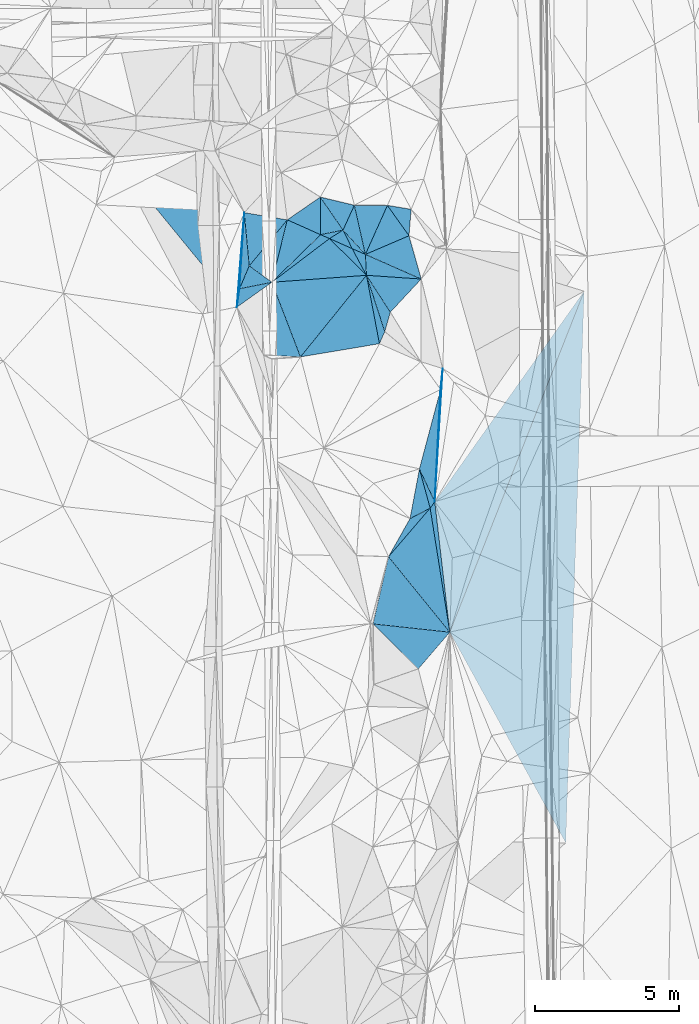
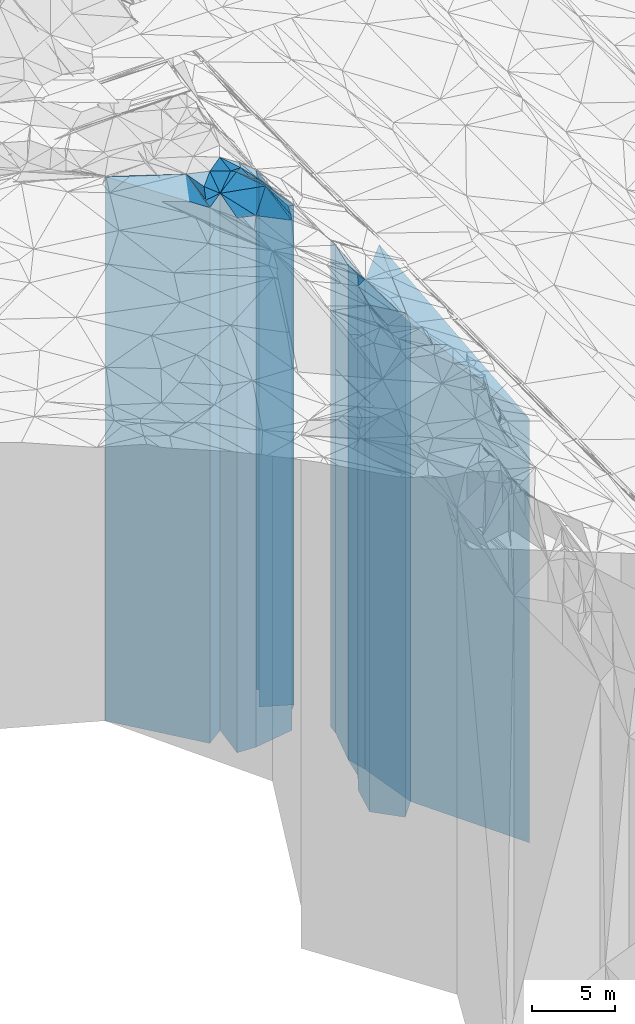
# One storey, part 207 of 275: 41 plates.
"""IFC2X3 building model written with IfcOpenShell, lengths in millimetres."""

from ifc_helpers import new_model, si_unit, frame, origin_with_axes, place, context, subcontext, project, spatial, faceted_brep, material, type_object, element, save


model = new_model("IFC2X3")

# Units and contexts
model_context = context("Model", 3, precision=1e-05, world=origin_with_axes())
body_context = subcontext(model_context, "Body", "Model", "MODEL_VIEW")
ifc_project = project(units=[si_unit("LENGTHUNIT", "METRE", prefix="MILLI"), si_unit("AREAUNIT", "SQUARE_METRE"), si_unit("VOLUMEUNIT", "CUBIC_METRE"), si_unit("MASSUNIT", "GRAM", prefix="KILO"), si_unit("TIMEUNIT", "SECOND"), si_unit("PLANEANGLEUNIT", "RADIAN"), si_unit("SOLIDANGLEUNIT", "STERADIAN"), si_unit("THERMODYNAMICTEMPERATUREUNIT", "DEGREE_CELSIUS"), si_unit("LUMINOUSINTENSITYUNIT", "LUMEN")], contexts=[model_context])

# Site, building, storey
site_placement = place(None, origin_with_axes())
site = spatial("IfcSite", under=ifc_project, at=site_placement, CompositionType="ELEMENT")
building_placement = place(site_placement, origin_with_axes())
building = spatial("IfcBuilding", under=site, at=building_placement, Name="Undefined", CompositionType="ELEMENT")
storey_placement = place(building_placement, origin_with_axes())
storey = spatial("IfcBuildingStorey", under=building, at=storey_placement, Name="Undefined", CompositionType="ELEMENT", Elevation=0.0)

# Plates
ifc_material = material()
plate_type_1 = type_object("IfcPlateType", PredefinedType="NOTDEFINED")
plate_1_placement = place(storey_placement, frame((-100408.430234477, 49733.2246878095, 26274.0), z_axis=(-0.393281517051527, 0.919418103120474, 0.0), x_axis=(0.919418103120471, 0.393281517051532, 0.0)))
element("IfcPlate", 1, at=plate_1_placement, inside=storey, type_object=plate_type_1, material=ifc_material, Name="00", context=body_context, shape_type="Brep", body=[
    faceted_brep([(0.0, -20336.0, -7.27595761418343e-12), (1374.74743652344, -19706.0, 1266.75537109374), (1374.74743652344, 18446.0, 1266.75537109374), (0.0, 18446.0, 0.0), (1650.12121582033, -18446.0, 1.64436642080545e-09), (1650.12121582033, 18446.0, 1.64436642080545e-09)], [[[0, 1, 2, 3]], [[1, 4, 5, 2]], [[4, 0, 3, 5]], [[5, 3, 2]], [[4, 1, 0]]]),
])
plate_type_2 = type_object("IfcPlateType", PredefinedType="NOTDEFINED")
plate_2_placement = place(storey_placement, frame((-99642.6539960685, 51438.5653437163, 26904.0), z_axis=(-0.00455352299844871, -0.999989632660411, 0.0), x_axis=(-0.99998963266041, 0.00455352299845431, 0.0)))
element("IfcPlate", 2, at=plate_2_placement, inside=storey, type_object=plate_type_2, material=ifc_material, Name="00", context=body_context, shape_type="Brep", body=[
    faceted_brep([(1.45519152283669e-11, -19076.0, -7.27595761418343e-12), (758.002990722671, -19706.0, 1708.80993652344), (758.002990722671, 19076.0, 1708.80993652344), (1.45519152283669e-11, 19076.0, -7.27595761418343e-12), (1150.39123535158, -20026.0, 2.77941580861807e-09), (1150.39123535158, 19076.0, 2.77941580861807e-09)], [[[0, 1, 2, 3]], [[1, 4, 5, 2]], [[4, 0, 3, 5]], [[5, 3, 2]], [[4, 1, 0]]]),
])
plate_type_3 = type_object("IfcPlateType", PredefinedType="NOTDEFINED")
plate_3_placement = place(storey_placement, frame((-98816.4230019084, 51300.9341543399, 26224.0), z_axis=(-0.164313055978836, -0.986408241872956, 0.0), x_axis=(-0.986408241872953, 0.164313055978852, 0.0)))
element("IfcPlate", 3, at=plate_3_placement, inside=storey, type_object=plate_type_3, material=ifc_material, Name="00", context=body_context, shape_type="Brep", body=[
    faceted_brep([(1.45519152283669e-11, -18396.0, -1.45519152283669e-11), (-77.1236801147315, -18496.0, 918.559692382798), (-77.1236801147315, 18396.0, 918.559692382798), (-1.45519152283669e-11, 18396.0, 1.45519152283669e-11), (837.615661621123, -19756.0, 2.09547579288483e-09), (837.615661621123, 18396.0, 2.09547579288483e-09)], [[[0, 1, 2, 3]], [[1, 4, 5, 2]], [[4, 0, 3, 5]], [[5, 3, 2]], [[4, 1, 0]]]),
])
plate_type_4 = type_object("IfcPlateType", PredefinedType="NOTDEFINED")
plate_4_placement = place(storey_placement, frame((-101969.740987989, 50420.5446503939, 27524.0), z_axis=(-0.200360374967368, 0.979722266840422, 0.0), x_axis=(0.979722266840424, 0.200360374967362, 0.0)))
element("IfcPlate", 4, at=plate_4_placement, inside=storey, type_object=plate_type_4, material=ifc_material, Name="00", context=body_context, shape_type="Brep", body=[
    faceted_brep([(0.0, -19816.0, 0.0), (252.533248901367, -20046.0, 1283.20959472656), (252.533248901367, 19696.0, 1283.20959472656), (0.0, 19696.0, 0.0), (798.310729980454, -19696.0, -2.00816430151463e-09), (798.310729980454, 19696.0, -2.00816430151463e-09)], [[[0, 1, 2, 3]], [[1, 4, 5, 2]], [[4, 0, 3, 5]], [[5, 3, 2]], [[4, 1, 0]]]),
])
plate_type_5 = type_object("IfcPlateType", PredefinedType="NOTDEFINED")
plate_5_placement = place(storey_placement, frame((-101969.740987989, 50420.5446503939, 27524.0), z_axis=(0.399271495028854, 0.91683274006627, 0.0), x_axis=(0.916832740066268, -0.399271495028857, 0.0)))
element("IfcPlate", 5, at=plate_5_placement, inside=storey, type_object=plate_type_5, material=ifc_material, Name="00", context=body_context, shape_type="Brep", body=[
    faceted_brep([(0.0, -19816.0, 0.0), (653.212341308594, -19696.0, 458.926574707033), (653.212341308594, 19696.0, 458.926574707033), (0.0, 19696.0, 0.0), (339.705749511704, -19726.0, -9.00399754755199e-10), (339.705749511704, 19696.0, -9.00399754755199e-10)], [[[0, 1, 2, 3]], [[1, 4, 5, 2]], [[4, 0, 3, 5]], [[5, 3, 2]], [[4, 1, 0]]]),
])
plate_type_6 = type_object("IfcPlateType", PredefinedType="NOTDEFINED")
plate_6_placement = place(storey_placement, frame((-101187.618203258, 50580.4944850444, 27304.0), z_axis=(0.531830128137156, -0.846851058218396, 0.0), x_axis=(-0.846851058218394, -0.531830128137159, 0.0)))
element("IfcPlate", 6, at=plate_6_placement, inside=storey, type_object=plate_type_6, material=ifc_material, Name="00", context=body_context, shape_type="Brep", body=[
    faceted_brep([(0.0, -19916.0, 0.0), (73.9490966796802, -19476.0, 716.820434570298), (73.9490966796802, 19476.0, 716.820434570298), (1.45519152283669e-11, 19476.0, -1.45519152283669e-11), (555.787719726563, -19946.0, -2.75031197816134e-09), (555.787719726563, 19476.0, -2.75031197816134e-09)], [[[0, 1, 2, 3]], [[1, 4, 5, 2]], [[4, 0, 3, 5]], [[5, 3, 2]], [[4, 1, 0]]]),
])
plate_type_7 = type_object("IfcPlateType", PredefinedType="NOTDEFINED")
plate_7_placement = place(storey_placement, frame((-103664.468272729, 48763.6803136547, 27539.0), z_axis=(-0.604209837063284, 0.796825246083456, 0.0), x_axis=(0.796825246083456, 0.604209837063283, 0.0)))
element("IfcPlate", 7, at=plate_7_placement, inside=storey, type_object=plate_type_7, material=ifc_material, Name="00", context=body_context, shape_type="Brep", body=[
    faceted_brep([(7.27595761418343e-12, -19761.0, -2.91038304567337e-11), (2351.49511718751, -19801.0, 296.260437011704), (2351.49511718751, 19711.0, 296.260437011704), (7.27595761418343e-12, 19711.0, 0.0), (2517.71728515625, -19711.0, -1.25874066725373e-08), (2517.71728515625, 19711.0, -1.25874066725373e-08)], [[[0, 1, 2, 3]], [[1, 4, 5, 2]], [[4, 0, 3, 5]], [[5, 3, 2]], [[4, 1, 0]]]),
])
plate_type_8 = type_object("IfcPlateType", PredefinedType="NOTDEFINED")
plate_8_placement = place(storey_placement, frame((-101979.432902652, 51728.3313557821, 27584.0), z_axis=(0.567831637088504, -0.823144721128301, 0.0), x_axis=(-0.823144721128298, -0.567831637088509, 0.0)))
element("IfcPlate", 8, at=plate_8_placement, inside=storey, type_object=plate_type_8, material=ifc_material, Name="00", context=body_context, shape_type="Brep", body=[
    faceted_brep([(0.0, -19986.0, 0.0), (734.624816894531, -19756.0, 1082.00109863281), (734.624816894531, 19756.0, 1082.00109863281), (-1.45519152283669e-11, 19756.0, -1.45519152283669e-11), (1394.45324707032, -19836.0, -1.16415321826935e-09), (1394.45324707032, 19756.0, -1.16415321826935e-09)], [[[0, 1, 2, 3]], [[1, 4, 5, 2]], [[4, 0, 3, 5]], [[5, 3, 2]], [[4, 1, 0]]]),
])
plate_type_9 = type_object("IfcPlateType", PredefinedType="NOTDEFINED")
plate_9_placement = place(storey_placement, frame((-100371.23257535, 49006.1646255344, 27184.0), z_axis=(-0.88121869398494, -0.472708803991926, 0.0), x_axis=(-0.472708803991917, 0.881218693984944, 0.0)))
element("IfcPlate", 9, at=plate_9_placement, inside=storey, type_object=plate_type_9, material=ifc_material, Name="00", context=body_context, shape_type="Brep", body=[
    faceted_brep([(-3.63797880709171e-12, -19356.0, 0.0), (1735.25646972656, -20066.0, 529.702880859346), (1735.25646972656, 19356.0, 529.702880859346), (0.0, 19356.0, -1.45519152283669e-11), (1053.04321289063, -19596.0, -5.82076609134674e-10), (1053.04321289063, 19356.0, -5.82076609134674e-10)], [[[0, 1, 2, 3]], [[1, 4, 5, 2]], [[4, 0, 3, 5]], [[5, 3, 2]], [[4, 1, 0]]]),
])
plate_type_10 = type_object("IfcPlateType", PredefinedType="NOTDEFINED")
plate_10_placement = place(storey_placement, frame((-100793.03330737, 51443.8036764334, 27379.0), z_axis=(-0.233211575093592, -0.972426018390276, 0.0), x_axis=(-0.972426018390275, 0.233211575093599, 0.0)))
element("IfcPlate", 10, at=plate_10_placement, inside=storey, type_object=plate_type_10, material=ifc_material, Name="00", context=body_context, shape_type="Brep", body=[
    faceted_brep([(1.45519152283669e-11, -19551.0, 3.63797880709171e-12), (182.370925903335, -19841.0, 931.526062011722), (182.370925903335, 19551.0, 931.526062011722), (8.18545231595635e-12, 19551.0, 0.0), (1220.04101562501, -20191.0, -2.24463292397559e-09), (1220.04101562501, 19551.0, -2.24463292397559e-09)], [[[0, 1, 2, 3]], [[1, 4, 5, 2]], [[4, 0, 3, 5]], [[5, 3, 2]], [[4, 1, 0]]]),
])
plate_type_11 = type_object("IfcPlateType", PredefinedType="NOTDEFINED")
plate_11_placement = place(storey_placement, frame((-100371.23257535, 49006.1646255344, 27184.0), z_axis=(-0.998693801805313, -0.0510949139900409, 0.0), x_axis=(-0.0510949139900386, 0.998693801805313, 0.0)))
element("IfcPlate", 11, at=plate_11_placement, inside=storey, type_object=plate_type_11, material=ifc_material, Name="00", context=body_context, shape_type="Brep", body=[
    faceted_brep([(-3.63797880709171e-12, -19356.0, 0.0), (952.183410644539, -19596.0, 449.718475341811), (952.183410644539, 19356.0, 449.718475341811), (0.0, 19356.0, -1.45519152283669e-11), (728.010986328132, -19426.0, 1.46974343806505e-09), (728.010986328132, 19356.0, 1.46974343806505e-09)], [[[0, 1, 2, 3]], [[1, 4, 5, 2]], [[4, 0, 3, 5]], [[5, 3, 2]], [[4, 1, 0]]]),
])
plate_type_12 = type_object("IfcPlateType", PredefinedType="NOTDEFINED")
plate_12_placement = place(storey_placement, frame((-101187.618203258, 50580.4944850444, 27219.0), z_axis=(0.896955755285538, 0.442120315140744, 0.0), x_axis=(0.442120315140746, -0.896955755285537, 0.0)))
element("IfcPlate", 12, at=plate_12_placement, inside=storey, type_object=plate_type_12, material=ifc_material, Name="00", context=body_context, shape_type="Brep", body=[
    faceted_brep([(8.18545231595635e-12, -20001.0, 0.0), (1104.45837402344, -19391.0, 324.301940917969), (1104.45837402344, 19391.0, 324.301940917969), (7.27595761418343e-12, 19391.0, 0.0), (720.624755859375, -19561.0, -4.65661287307739e-10), (720.624755859375, 19391.0, -4.65661287307739e-10)], [[[0, 1, 2, 3]], [[1, 4, 5, 2]], [[4, 0, 3, 5]], [[5, 3, 2]], [[4, 1, 0]]]),
])
plate_type_13 = type_object("IfcPlateType", PredefinedType="NOTDEFINED")
plate_13_placement = place(storey_placement, frame((-100793.03330737, 51443.8036764334, 27219.0), z_axis=(0.909502651009569, -0.415698121004374, 0.0), x_axis=(-0.415698121004381, -0.909502651009566, 0.0)))
element("IfcPlate", 13, at=plate_13_placement, inside=storey, type_object=plate_type_13, material=ifc_material, Name="00", context=body_context, shape_type="Brep", body=[
    faceted_brep([(-9.09494701772928e-13, -19711.0, -1.45519152283669e-11), (1395.89733886719, -19391.0, 1060.88195800781), (1395.89733886719, 19391.0, 1060.88195800781), (7.27595761418343e-12, 19391.0, 0.0), (949.210205078124, -20001.0, -2.6775524020195e-09), (949.210205078124, 19391.0, -2.6775524020195e-09)], [[[0, 1, 2, 3]], [[1, 4, 5, 2]], [[4, 0, 3, 5]], [[5, 3, 2]], [[4, 1, 0]]]),
])
plate_type_14 = type_object("IfcPlateType", PredefinedType="NOTDEFINED")
plate_14_placement = place(storey_placement, frame((-103664.468272729, 48763.6803136547, 27564.0), z_axis=(-0.699073984699882, 0.715049343693027, 0.0), x_axis=(0.715049343204323, 0.699073985199754, 0.0)))
element("IfcPlate", 14, at=plate_14_placement, inside=storey, type_object=plate_type_14, material=ifc_material, Name="00", context=body_context, shape_type="Brep", body=[
    faceted_brep([(0.0, -19736.0, 0.0), (1903.0968009342, -19856.0, 1178.14367675781), (1903.0968009342, 19736.0, 1178.14367675781), (0.0, 19736.0, 0.0), (2370.08447265626, -19776.0, 2.47382558882236e-10), (2370.08447265626, 19736.0, 2.47382558882236e-10)], [[[0, 1, 2, 3]], [[1, 4, 5, 2]], [[4, 0, 3, 5]], [[5, 3, 2]], [[4, 1, 0]]]),
])
plate_type_15 = type_object("IfcPlateType", PredefinedType="NOTDEFINED")
plate_15_placement = place(storey_placement, frame((-99734.2828294801, 47046.3444753073, 26609.0), z_axis=(-0.961490975586377, 0.274836503881774, 0.0), x_axis=(0.274836503881771, 0.961490975586378, 0.0)))
element("IfcPlate", 15, at=plate_15_placement, inside=storey, type_object=plate_type_15, material=ifc_material, Name="00", context=body_context, shape_type="Brep", body=[
    faceted_brep([(1.45519152283669e-11, -18781.0, 4.54747350886464e-12), (1709.29235839843, -19931.0, 1151.05151367186), (1709.29235839843, 18781.0, 1151.05151367186), (-1.45519152283669e-11, 18781.0, 4.54747350886464e-13), (702.922485351559, -18951.0, -2.4156179279089e-09), (702.922485351559, 18781.0, -2.4156179279089e-09)], [[[0, 1, 2, 3]], [[1, 4, 5, 2]], [[4, 0, 3, 5]], [[5, 3, 2]], [[4, 1, 0]]]),
])
plate_type_16 = type_object("IfcPlateType", PredefinedType="NOTDEFINED")
plate_16_placement = place(storey_placement, frame((-100408.430234477, 49733.2246878095, 26174.0), z_axis=(0.998693801805313, 0.0510949139900409, 0.0), x_axis=(0.0510949139900391, -0.998693801805313, 0.0)))
element("IfcPlate", 16, at=plate_16_placement, inside=storey, type_object=plate_type_16, material=ifc_material, Name="00", context=body_context, shape_type="Brep", body=[
    faceted_brep([(-9.09494701772928e-13, -20436.0, 1.45519152283669e-11), (955.754821777351, -18346.0, 1896.39990234374), (955.754821777351, 18346.0, 1896.39990234374), (-2.91038304567337e-11, 18346.0, -2.91038304567337e-11), (728.010986328125, -20366.0, 1.45519152283669e-09), (728.010986328125, 18346.0, 1.45519152283669e-09)], [[[0, 1, 2, 3]], [[1, 4, 5, 2]], [[4, 0, 3, 5]], [[5, 3, 2]], [[4, 1, 0]]]),
])
plate_type_17 = type_object("IfcPlateType", PredefinedType="NOTDEFINED")
plate_17_placement = place(storey_placement, frame((-99919.8785007401, 46625.3287430484, 26564.0), z_axis=(-0.915035399072081, 0.403373547031778, 0.0), x_axis=(0.403373547031776, 0.915035399072081, 0.0)))
element("IfcPlate", 17, at=plate_17_placement, inside=storey, type_object=plate_type_17, material=ifc_material, Name="00", context=body_context, shape_type="Brep", body=[
    faceted_brep([(-1.45519152283669e-11, -18736.0, -1.45519152283669e-11), (1996.48486328124, -19976.0, 1373.37121582031), (1996.48486328124, 18736.0, 1373.37121582031), (-5.91171556152403e-12, 18736.0, 1.45519152283669e-11), (460.108673095697, -18826.0, 6.25732354819775e-10), (460.108673095697, 18736.0, 6.25732354819775e-10)], [[[0, 1, 2, 3]], [[1, 4, 5, 2]], [[4, 0, 3, 5]], [[5, 3, 2]], [[4, 1, 0]]]),
])
plate_type_18 = type_object("IfcPlateType", PredefinedType="NOTDEFINED")
plate_18_placement = place(storey_placement, frame((-100371.23257535, 49006.1646255344, 26174.0), z_axis=(0.839767991664275, 0.542945411782944, 0.0), x_axis=(0.542945411782941, -0.839767991664277, 0.0)))
element("IfcPlate", 18, at=plate_18_placement, inside=storey, type_object=plate_type_18, material=ifc_material, Name="00", context=body_context, shape_type="Brep", body=[
    faceted_brep([(-1.45519152283669e-11, -20366.0, -1.45519152283669e-11), (1144.24645996094, -18346.0, 1529.34631347656), (1144.24645996094, 18346.0, 1529.34631347656), (-2.91038304567337e-11, 18346.0, -2.91038304567337e-11), (1528.95385742186, -19386.0, 1.74622982740402e-09), (1528.95385742186, 18346.0, 1.74622982740402e-09)], [[[0, 1, 2, 3]], [[1, 4, 5, 2]], [[4, 0, 3, 5]], [[5, 3, 2]], [[4, 1, 0]]]),
])
plate_type_19 = type_object("IfcPlateType", PredefinedType="NOTDEFINED")
plate_19_placement = place(storey_placement, frame((-104452.30723777, 49333.7765907551, 27564.0), z_axis=(0.920337161759967, -0.391125949897994, 0.0), x_axis=(-0.391125949897986, -0.920337161759971, 0.0)))
element("IfcPlate", 19, at=plate_19_placement, inside=storey, type_object=plate_type_19, material=ifc_material, Name="00", context=body_context, shape_type="Brep", body=[
    faceted_brep([(1.45519152283669e-11, -20166.0, -1.45519152283669e-11), (216.536529541008, -19736.0, 948.056945800781), (216.536529541008, 19736.0, 948.056945800781), (0.0, 19736.0, 0.0), (863.133850097649, -19766.0, 1.32422428578138e-09), (863.133850097649, 19736.0, 1.32422428578138e-09)], [[[0, 1, 2, 3]], [[1, 4, 5, 2]], [[4, 0, 3, 5]], [[5, 3, 2]], [[4, 1, 0]]]),
])
plate_type_20 = type_object("IfcPlateType", PredefinedType="NOTDEFINED")
plate_20_placement = place(storey_placement, frame((-103127.269773389, 50936.516656389, 27624.0), z_axis=(-0.165444380043675, -0.986219122260344, 0.0), x_axis=(-0.986219122260344, 0.165444380043675, 0.0)))
element("IfcPlate", 20, at=plate_20_placement, inside=storey, type_object=plate_type_20, material=ifc_material, Name="00", context=body_context, shape_type="Brep", body=[
    faceted_brep([(-7.27595761418343e-12, -19796.0, -1.45519152283669e-11), (1041.61291503908, -20106.0, 1799.87292480468), (1041.61291503908, 19796.0, 1799.87292480468), (-7.27595761418343e-12, 19796.0, -1.45519152283669e-11), (1519.6240234375, -19956.0, -4.86761564388871e-09), (1519.6240234375, 19796.0, -4.86761564388871e-09)], [[[0, 1, 2, 3]], [[1, 4, 5, 2]], [[4, 0, 3, 5]], [[5, 3, 2]], [[4, 1, 0]]]),
])
plate_type_21 = type_object("IfcPlateType", PredefinedType="NOTDEFINED")
plate_21_placement = place(storey_placement, frame((-103127.269773389, 50936.516656389, 27564.0), z_axis=(0.77071736266349, -0.637177170721797, 0.0), x_axis=(-0.637177170721795, -0.770717362663492, 0.0)))
element("IfcPlate", 21, at=plate_21_placement, inside=storey, type_object=plate_type_21, material=ifc_material, Name="00", context=body_context, shape_type="Brep", body=[
    faceted_brep([(1.09139364212751e-11, -19856.0, 1.45519152283669e-11), (2016.93334960938, -19736.0, 970.453491210923), (2016.93334960938, 19736.0, 970.453491210923), (0.0, 19736.0, 0.0), (2079.54321289063, -20166.0, 4.32191882282496e-09), (2079.54321289063, 19736.0, 4.32191882282496e-09)], [[[0, 1, 2, 3]], [[1, 4, 5, 2]], [[4, 0, 3, 5]], [[5, 3, 2]], [[4, 1, 0]]]),
])
plate_type_22 = type_object("IfcPlateType", PredefinedType="NOTDEFINED")
plate_22_placement = place(storey_placement, frame((-100371.23257535, 49006.1646255344, 26564.0), z_axis=(0.77768926512532, -0.628648874101307, 0.0), x_axis=(-0.628648874101305, -0.777689265125321, 0.0)))
element("IfcPlate", 22, at=plate_22_placement, inside=storey, type_object=plate_type_22, material=ifc_material, Name="00", context=body_context, shape_type="Brep", body=[
    faceted_brep([(-1.45519152283669e-11, -19976.0, 0.0), (1567.80725097655, -18736.0, 1847.72302246094), (1567.80725097655, 18736.0, 1847.72302246094), (-5.91171556152403e-12, 18736.0, 1.45519152283669e-11), (3653.95678710938, -20316.0, 1.9950675778091e-08), (3653.95678710938, 18736.0, 1.9950675778091e-08)], [[[0, 1, 2, 3]], [[1, 4, 5, 2]], [[4, 0, 3, 5]], [[5, 3, 2]], [[4, 1, 0]]]),
])
plate_type_23 = type_object("IfcPlateType", PredefinedType="NOTDEFINED")
plate_23_placement = place(storey_placement, frame((-101658.287629832, 50284.9098256165, 27184.0), z_axis=(0.604209837063284, -0.796825246083456, 0.0), x_axis=(-0.796825246083457, -0.604209837063283, 0.0)))
element("IfcPlate", 23, at=plate_23_placement, inside=storey, type_object=plate_type_23, material=ifc_material, Name="00", context=body_context, shape_type="Brep", body=[
    faceted_brep([(1.45519152283669e-11, -20066.0, 0.0), (-252.927536010728, -19356.0, 1796.58776855469), (-252.927536010728, 19356.0, 1796.58776855469), (0.0, 19356.0, -1.45519152283669e-11), (2517.71728515626, -20116.0, -1.2572854757309e-08), (2517.71728515626, 19356.0, -1.2572854757309e-08)], [[[0, 1, 2, 3]], [[1, 4, 5, 2]], [[4, 0, 3, 5]], [[5, 3, 2]], [[4, 1, 0]]]),
])
plate_type_24 = type_object("IfcPlateType", PredefinedType="NOTDEFINED")
plate_24_placement = place(storey_placement, frame((-104452.30723777, 49333.7765907551, 27579.0), z_axis=(-0.995643309864272, -0.0932437639872878, 0.0), x_axis=(-0.0932437639872891, 0.995643309864272, 0.0)))
element("IfcPlate", 24, at=plate_24_placement, inside=storey, type_object=plate_type_24, material=ifc_material, Name="00", context=body_context, shape_type="Brep", body=[
    faceted_brep([(0.0, -20151.0, 0.0), (-759.434753417969, -19751.0, 410.193664550767), (-759.434753417969, 19751.0, 410.193664550767), (0.0, 19751.0, 0.0), (1862.2666015625, -20001.0, 5.42786438018084e-09), (1862.2666015625, 19751.0, 5.42786438018084e-09)], [[[0, 1, 2, 3]], [[1, 4, 5, 2]], [[4, 0, 3, 5]], [[5, 3, 2]], [[4, 1, 0]]]),
])
plate_type_25 = type_object("IfcPlateType", PredefinedType="NOTDEFINED")
plate_25_placement = place(storey_placement, frame((-103954.609665335, 46229.9246087185, 27354.0), z_axis=(0.0507793469886415, 0.99870989677654, 0.0), x_axis=(0.99870989677654, -0.0507793469886369, 0.0)))
element("IfcPlate", 25, at=plate_25_placement, inside=storey, type_object=plate_type_25, material=ifc_material, Name="00", context=body_context, shape_type="Brep", body=[
    faceted_brep([(-7.27595761418343e-12, -19796.0, -1.45519152283669e-11), (161.104614257813, -19946.0, 2545.21997070313), (161.104614257813, 19526.0, 2545.21997070313), (0.0, 19526.0, 0.0), (1287.98291015626, -19526.0, -1.54250301420689e-09), (1287.98291015626, 19526.0, -1.54250301420689e-09)], [[[0, 1, 2, 3]], [[1, 4, 5, 2]], [[4, 0, 3, 5]], [[5, 3, 2]], [[4, 1, 0]]]),
])
plate_type_26 = type_object("IfcPlateType", PredefinedType="NOTDEFINED")
plate_26_placement = place(storey_placement, frame((-104789.901274975, 48539.4024559526, 27510.0), z_axis=(-0.998089556565869, 0.0617837929731288, 0.0), x_axis=(0.061783792973124, 0.99808955656587, 0.0)))
element("IfcPlate", 26, at=plate_26_placement, inside=storey, type_object=plate_type_26, material=ifc_material, Name="00", context=body_context, shape_type="Brep", body=[
    faceted_brep([(0.0, -19820.0, 0.0), (-646.142944335945, -19682.0, 51.4614677429345), (-646.142944335945, 19682.0, 51.4614677429345), (0.0, 19682.0, 0.0), (2653.59692382813, -20070.0, -4.918547347188e-09), (2653.59692382813, 19682.0, -4.918547347188e-09)], [[[0, 1, 2, 3]], [[1, 4, 5, 2]], [[4, 0, 3, 5]], [[5, 3, 2]], [[4, 1, 0]]]),
])
plate_type_27 = type_object("IfcPlateType", PredefinedType="NOTDEFINED")
plate_27_placement = place(storey_placement, frame((-97792.7201179677, 45029.2093193832, 25712.5), z_axis=(0.966374354323386, -0.257139276086051, 0.0), x_axis=(-0.257139276086048, -0.966374354323387, 0.0)))
element("IfcPlate", 27, at=plate_27_placement, inside=storey, type_object=plate_type_27, material=ifc_material, Name="00", context=body_context, shape_type="Brep", body=[
    faceted_brep([(3.63797880709171e-12, -17987.5, -1.45519152283669e-11), (3827.43359375, -17884.5, 810.25463867186), (3827.43359375, 17884.5, 810.25463867186), (3.63797880709171e-12, 17884.5, -1.45519152283669e-11), (2859.54541015626, -18427.5, -2.86672729998827e-09), (2859.54541015626, 17884.5, -2.86672729998827e-09)], [[[0, 1, 2, 3]], [[1, 4, 5, 2]], [[4, 0, 3, 5]], [[5, 3, 2]], [[4, 1, 0]]]),
])
plate_type_28 = type_object("IfcPlateType", PredefinedType="NOTDEFINED")
plate_28_placement = place(storey_placement, frame((-103664.468272729, 48763.6803136547, 27510.0), z_axis=(0.19543844600118, -0.980715970005916, 0.0), x_axis=(-0.980715970005916, -0.195438446001176, 0.0)))
element("IfcPlate", 28, at=plate_28_placement, inside=storey, type_object=plate_type_28, material=ifc_material, Name="00", context=body_context, shape_type="Brep", body=[
    faceted_brep([(2.91038304567337e-11, -19790.0, -1.45519152283669e-11), (1362.50512695315, -19682.0, 611.513488769517), (1362.50512695315, 19682.0, 611.513488769517), (0.0, 19682.0, 0.0), (1147.56262207034, -19820.0, -3.18686943501234e-09), (1147.56262207034, 19682.0, -3.18686943501234e-09)], [[[0, 1, 2, 3]], [[1, 4, 5, 2]], [[4, 0, 3, 5]], [[5, 3, 2]], [[4, 1, 0]]]),
])
plate_type_29 = type_object("IfcPlateType", PredefinedType="NOTDEFINED")
plate_29_placement = place(storey_placement, frame((-98153.9293885031, 40900.4773272482, 25712.5), z_axis=(-0.810758244851503, 0.585381130892781, 0.0), x_axis=(0.585381130892764, 0.810758244851515, 0.0)))
element("IfcPlate", 29, at=plate_29_placement, inside=storey, type_object=plate_type_29, material=ifc_material, Name="00", context=body_context, shape_type="Brep", body=[
    faceted_brep([(1.45519152283669e-11, -18107.5, -1.45519152283669e-11), (887.974670410149, -18427.5, 1102.54296874999), (887.974670410149, 17884.5, 1102.54296874999), (3.63797880709171e-12, 17884.5, -1.45519152283669e-11), (273.386169433601, -17884.5, -4.80213202536106e-10), (273.386169433601, 17884.5, -4.80213202536106e-10)], [[[0, 1, 2, 3]], [[1, 4, 5, 2]], [[4, 0, 3, 5]], [[5, 3, 2]], [[4, 1, 0]]]),
])
plate_type_30 = type_object("IfcPlateType", PredefinedType="NOTDEFINED")
plate_30_placement = place(storey_placement, frame((-98856.2308319929, 40535.2750785255, 25824.0), z_axis=(-0.461358204076558, 0.887213958147218, 0.0), x_axis=(0.887213958147218, 0.461358204076557, 0.0)))
element("IfcPlate", 30, at=plate_30_placement, inside=storey, type_object=plate_type_30, material=ifc_material, Name="00", context=body_context, shape_type="Brep", body=[
    faceted_brep([(1.45519152283669e-11, -18776.0, -1.45519152283669e-11), (1089.59204101564, -18316.0, 1383.93981933592), (1089.59204101564, 17996.0, 1383.93981933592), (1.45519152283669e-11, 17996.0, 0.0), (791.580688476577, -17996.0, 3.30328475683928e-09), (791.580688476577, 17996.0, 3.30328475683928e-09)], [[[0, 1, 2, 3]], [[1, 4, 5, 2]], [[4, 0, 3, 5]], [[5, 3, 2]], [[4, 1, 0]]]),
])
plate_type_31 = type_object("IfcPlateType", PredefinedType="NOTDEFINED")
plate_31_placement = place(storey_placement, frame((-99604.0225451746, 39209.6403046542, 25407.0), z_axis=(0.776264185970933, 0.630407735976395, 0.0), x_axis=(0.630407735976394, -0.776264185970934, 0.0)))
element("IfcPlate", 31, at=plate_31_placement, inside=storey, type_object=plate_type_31, material=ifc_material, Name="00", context=body_context, shape_type="Brep", body=[
    faceted_brep([(1.45519152283669e-11, -19433.0, 0.0), (-398.386291503892, -18413.0, 2191.57202148438), (-398.386291503892, 17579.0, 2191.57202148438), (1.45519152283669e-11, 17579.0, 0.0), (3384.83032226564, -17579.0, 1.80589267984033e-08), (3384.83032226564, 17579.0, 1.80589267984033e-08)], [[[0, 1, 2, 3]], [[1, 4, 5, 2]], [[4, 0, 3, 5]], [[5, 3, 2]], [[4, 1, 0]]]),
])
plate_type_32 = type_object("IfcPlateType", PredefinedType="NOTDEFINED")
plate_32_placement = place(storey_placement, frame((-98153.9293885031, 40900.4773272482, 25407.0), z_axis=(0.987696497283402, 0.156382957044873, 0.0), x_axis=(0.156382957044872, -0.987696497283402, 0.0)))
element("IfcPlate", 32, at=plate_32_placement, inside=storey, type_object=plate_type_32, material=ifc_material, Name="00", context=body_context, shape_type="Brep", body=[
    faceted_brep([(0.0, -18413.0, 0.0), (-193.896255493157, -18190.0, 192.728408813477), (-193.896255493157, 17579.0, 192.728408813477), (1.45519152283669e-11, 17579.0, 0.0), (4372.15234375001, -17579.0, 1.21654011309147e-08), (4372.15234375001, 17579.0, 1.21654011309147e-08)], [[[0, 1, 2, 3]], [[1, 4, 5, 2]], [[4, 0, 3, 5]], [[5, 3, 2]], [[4, 1, 0]]]),
])
plate_type_33 = type_object("IfcPlateType", PredefinedType="NOTDEFINED")
plate_33_placement = place(storey_placement, frame((-100144.582474531, 36871.3086423841, 25407.0), z_axis=(0.107506998965177, 0.994204327677918, 0.0), x_axis=(0.994204327677919, -0.107506998965172, 0.0)))
element("IfcPlate", 33, at=plate_33_placement, inside=storey, type_object=plate_type_33, material=ifc_material, Name="00", context=body_context, shape_type="Brep", body=[
    faceted_brep([(-1.45519152283669e-11, -19663.0, -7.27595761418343e-12), (286.040008544893, -19433.0, 2382.89355468749), (286.040008544893, 17579.0, 2382.89355468749), (1.45519152283669e-11, 17579.0, 0.0), (2689.97338867188, -17579.0, -3.63797880709171e-11), (2689.97338867188, 17579.0, -3.63797880709171e-11)], [[[0, 1, 2, 3]], [[1, 4, 5, 2]], [[4, 0, 3, 5]], [[5, 3, 2]], [[4, 1, 0]]]),
])
plate_type_34 = type_object("IfcPlateType", PredefinedType="NOTDEFINED")
plate_34_placement = place(storey_placement, frame((-98153.9293885031, 40900.4773272482, 25824.0), z_axis=(0.461358204076558, -0.887213958147218, 0.0), x_axis=(-0.887213958147222, -0.46135820407655, 0.0)))
element("IfcPlate", 34, at=plate_34_placement, inside=storey, type_object=plate_type_34, material=ifc_material, Name="00", context=body_context, shape_type="Brep", body=[
    faceted_brep([(1.45519152283669e-11, -17996.0, 0.0), (2066.62451171876, -19016.0, 831.12182617186), (2066.62451171876, 17996.0, 831.12182617186), (1.45519152283669e-11, 17996.0, 0.0), (791.580688476563, -18776.0, 3.31783667206764e-09), (791.580688476577, 17996.0, 3.30328475683928e-09)], [[[0, 1, 2, 3]], [[1, 4, 5, 2]], [[4, 0, 3, 5]], [[5, 3, 2]], [[4, 1, 0]]]),
])
plate_type_35 = type_object("IfcPlateType", PredefinedType="NOTDEFINED")
plate_35_placement = place(storey_placement, frame((-109158.034310309, 53119.1281885295, 27510.0), z_axis=(0.77361231877338, 0.633659198814374, 0.0), x_axis=(0.633659198814377, -0.773612318773378, 0.0)))
element("IfcPlate", 35, at=plate_35_placement, inside=storey, type_object=plate_type_35, material=ifc_material, Name="00", context=body_context, shape_type="Brep", body=[
    faceted_brep([(0.0, -20311.0, -7.27595761418343e-12), (4365.79443359375, -20070.0, 2282.35327148437), (4365.79443359375, 19682.0, 2282.35327148437), (0.0, 19682.0, 0.0), (6749.4462890625, -19682.0, -2.45563569478691e-08), (6749.4462890625, 19682.0, -2.45563569478691e-08)], [[[0, 1, 2, 3]], [[1, 4, 5, 2]], [[4, 0, 3, 5]], [[5, 3, 2]], [[4, 1, 0]]]),
])
plate_type_36 = type_object("IfcPlateType", PredefinedType="NOTDEFINED")
plate_36_placement = place(storey_placement, frame((-98891.2789239202, 50382.1868599548, 26174.0), z_axis=(0.393281517051527, -0.919418103120474, 0.0), x_axis=(-0.919418103120471, -0.393281517051532, 0.0)))
element("IfcPlate", 36, at=plate_36_placement, inside=storey, type_object=plate_type_36, material=ifc_material, Name="00", context=body_context, shape_type="Brep", body=[
    faceted_brep([(0.0, -18546.0, 0.0), (201.197341918931, -18346.0, 1552.55261230469), (201.197341918931, 18346.0, 1552.55261230469), (-2.91038304567337e-11, 18346.0, -2.91038304567337e-11), (1650.12121582031, -20436.0, 1.64436642080545e-09), (1650.12121582031, 18346.0, 1.64436642080545e-09)], [[[0, 1, 2, 3]], [[1, 4, 5, 2]], [[4, 0, 3, 5]], [[5, 3, 2]], [[4, 1, 0]]]),
])
plate_type_37 = type_object("IfcPlateType", PredefinedType="NOTDEFINED")
plate_37_placement = place(storey_placement, frame((-98566.6692560539, 35305.6810126596, 25407.0), z_axis=(-0.758556874070326, 0.651606836060408, 0.0), x_axis=(0.651606836060407, 0.758556874070327, 0.0)))
element("IfcPlate", 37, at=plate_37_placement, inside=storey, type_object=plate_type_37, material=ifc_material, Name="00", context=body_context, shape_type="Brep", body=[
    faceted_brep([(7.27595761418343e-12, -19483.0, 1.45519152283669e-11), (159.438568115234, -19663.0, 2217.11059570313), (159.438568115234, 17579.0, 2217.11059570313), (1.45519152283669e-11, 17579.0, 0.0), (1682.71716308594, -17579.0, 4.22005541622639e-10), (1682.71716308594, 17579.0, 4.22005541622639e-10)], [[[0, 1, 2, 3]], [[1, 4, 5, 2]], [[4, 0, 3, 5]], [[5, 3, 2]], [[4, 1, 0]]]),
])
plate_type_38 = type_object("IfcPlateType", PredefinedType="NOTDEFINED")
plate_38_placement = place(storey_placement, frame((-92793.4238682116, 48453.3860097972, 23411.5), z_axis=(0.930402642910081, -0.366539113964577, 0.0), x_axis=(-0.366539113964576, -0.930402642910081, 0.0)))
element("IfcPlate", 38, at=plate_38_placement, inside=storey, type_object=plate_type_38, material=ifc_material, Name="00", context=body_context, shape_type="Brep", body=[
    faceted_brep([(-5.45696821063757e-12, -16523.5109863281, -1.45519152283669e-11), (18101.154296875, -15583.5, 6441.57519531249), (18101.154296875, 15583.5, 6441.57519531249), (0.0, 15583.5, 0.0), (12759.2802734375, -19574.5109863281, -2.53348844125867e-08), (12759.2802734375, 15583.5, -2.53348844125867e-08)], [[[0, 1, 2, 3]], [[1, 4, 5, 2]], [[4, 0, 3, 5]], [[5, 3, 2]], [[4, 1, 0]]]),
])
plate_type_39 = type_object("IfcPlateType", PredefinedType="NOTDEFINED")
plate_39_placement = place(storey_placement, frame((-92793.4238682116, 48453.3860097972, 23881.5), z_axis=(0.815630955557685, -0.578572505686243, 0.0), x_axis=(-0.578572505686242, -0.815630955557686, 0.0)))
element("IfcPlate", 39, at=plate_39_placement, inside=storey, type_object=plate_type_39, material=ifc_material, Name="00", context=body_context, shape_type="Brep", body=[
    faceted_brep([(1.45519152283669e-11, -16053.5, -7.27595761418343e-12), (12388.427734375, -19104.5, 3053.86669921875), (12388.427734375, 16053.5, 3053.86669921875), (-7.27595761418343e-12, 16053.5, -1.45519152283669e-11), (8988.4501953125, -19715.5, 1.95868778973818e-08), (8988.4501953125, 16053.5, 1.95868778973818e-08)], [[[0, 1, 2, 3]], [[1, 4, 5, 2]], [[4, 0, 3, 5]], [[5, 3, 2]], [[4, 1, 0]]]),
])
plate_type_40 = type_object("IfcPlateType", PredefinedType="NOTDEFINED")
plate_40_placement = place(storey_placement, frame((-97792.7201179677, 45029.2093193832, 25695.5), z_axis=(0.998677039503882, -0.0514215010259417, 0.0), x_axis=(-0.0514215010259442, -0.998677039503882, 0.0)))
element("IfcPlate", 40, at=plate_40_placement, inside=storey, type_object=plate_type_40, material=ifc_material, Name="00", context=body_context, shape_type="Brep", body=[
    faceted_brep([(7.27595761418343e-12, -18004.5, 1.45519152283669e-11), (-726.881591796875, -17867.5, 37.2582817077637), (-726.881591796875, 17867.5, 37.2582817077637), (-1.45519152283669e-11, 17867.5, 3.63797880709171e-12), (3912.25756835938, -17901.5, 1.19034666568041e-08), (3912.25756835938, 17867.5, 1.19034666568041e-08)], [[[0, 1, 2, 3]], [[1, 4, 5, 2]], [[4, 0, 3, 5]], [[5, 3, 2]], [[4, 1, 0]]]),
])
plate_type_41 = type_object("IfcPlateType", PredefinedType="NOTDEFINED")
plate_41_placement = place(storey_placement, frame((-100371.23257535, 49006.1646255344, 27184.0), z_axis=(0.0734322340050858, -0.997300209068976, 0.0), x_axis=(-0.997300209068976, -0.073432234005079, 0.0)))
element("IfcPlate", 41, at=plate_41_placement, inside=storey, type_object=plate_type_41, material=ifc_material, Name="00", context=body_context, shape_type="Brep", body=[
    faceted_brep([(-3.63797880709171e-12, -19356.0, 0.0), (2499.5224609375, -19696.0, 2665.29321289062), (2499.5224609375, 19356.0, 2665.29321289062), (0.0, 19356.0, -1.45519152283669e-11), (3302.15087890624, -20116.0, 9.82981873676181e-09), (3302.15087890624, 19356.0, 9.82981873676181e-09)], [[[0, 1, 2, 3]], [[1, 4, 5, 2]], [[4, 0, 3, 5]], [[5, 3, 2]], [[4, 1, 0]]]),
])

save(model, "model.ifc")
